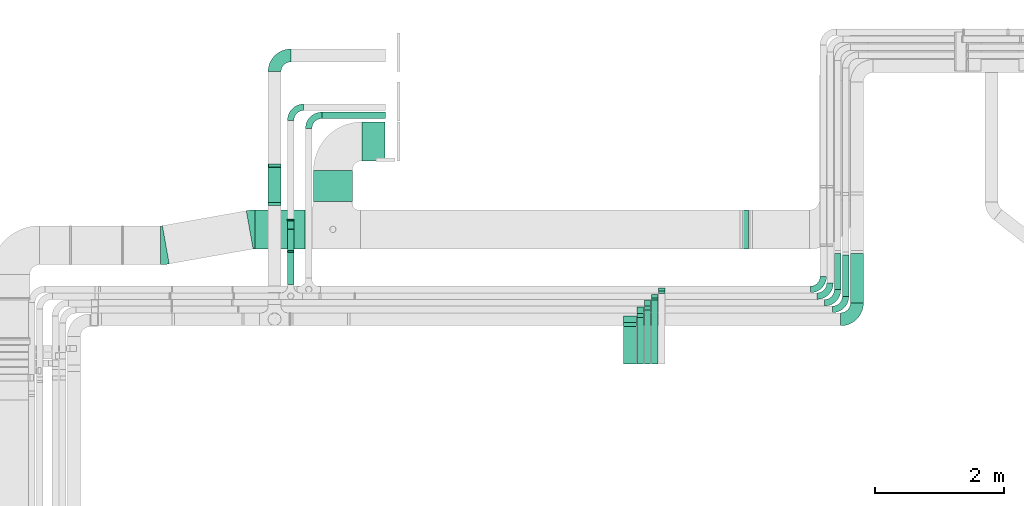
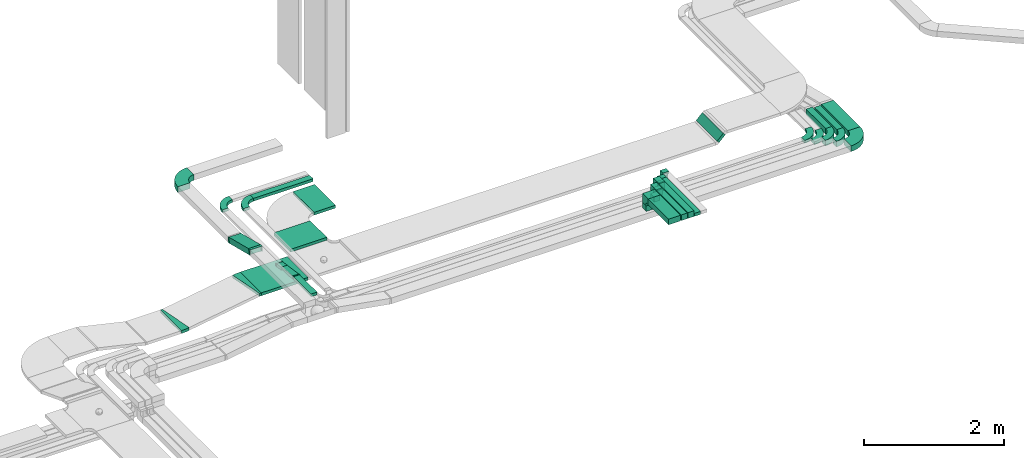
# One storey, part 10 of 28: 21 flow segments, 19 flow fittings.
"""IFC2X3 building model written with IfcOpenShell, lengths in millimetres."""

from ifc_helpers import new_model, entity, si_unit, converted_unit, derived_unit, direction, frame, frame_2d, origin, origin_2d_with_axis, place, context, subcontext, project, spatial, polyline, circle_curve, parameter, trimmed, segment, composite_curve, rectangle, outline, extrude, faceted_brep, source, transform, mapped, material, type_object, type_shapes, element, save


model = new_model("IFC2X3")

# Units and contexts
model_context = context("Model", 3, precision=0.01, world=origin(), true_north=direction((6.12303176911189e-17, 1.0)))
body_context = subcontext(model_context, "Body", "Model", "MODEL_VIEW")
ifc_project = project(units=[si_unit("LENGTHUNIT", "METRE", prefix="MILLI"), si_unit("AREAUNIT", "SQUARE_METRE"), si_unit("VOLUMEUNIT", "CUBIC_METRE"), converted_unit("PLANEANGLEUNIT", "DEGREE", entity("IfcRatioMeasure", 0.0174532925199433), si_unit("PLANEANGLEUNIT", "RADIAN"), dimensions=[0, 0, 0, 0, 0, 0, 0]), si_unit("MASSUNIT", "GRAM", prefix="KILO"), derived_unit("MASSDENSITYUNIT", [(si_unit("MASSUNIT", "GRAM", prefix="KILO"), 1), (si_unit("LENGTHUNIT", "METRE"), -3)]), derived_unit("MOMENTOFINERTIAUNIT", [(si_unit("LENGTHUNIT", "METRE"), 4)]), si_unit("TIMEUNIT", "SECOND"), si_unit("FREQUENCYUNIT", "HERTZ"), si_unit("THERMODYNAMICTEMPERATUREUNIT", "DEGREE_CELSIUS"), derived_unit("THERMALTRANSMITTANCEUNIT", [(si_unit("MASSUNIT", "GRAM", prefix="KILO"), 1), (si_unit("THERMODYNAMICTEMPERATUREUNIT", "KELVIN"), -1), (si_unit("TIMEUNIT", "SECOND"), -3)]), derived_unit("VOLUMETRICFLOWRATEUNIT", [(si_unit("LENGTHUNIT", "METRE"), 3), (si_unit("TIMEUNIT", "SECOND"), -1)]), derived_unit("MASSFLOWRATEUNIT", [(si_unit("MASSUNIT", "GRAM", prefix="KILO"), 1), (si_unit("TIMEUNIT", "SECOND"), -1)]), derived_unit("ROTATIONALFREQUENCYUNIT", [(si_unit("TIMEUNIT", "SECOND"), -1)]), si_unit("ELECTRICCURRENTUNIT", "AMPERE"), si_unit("ELECTRICVOLTAGEUNIT", "VOLT"), si_unit("POWERUNIT", "WATT"), si_unit("FORCEUNIT", "NEWTON", prefix="KILO"), si_unit("ILLUMINANCEUNIT", "LUX"), si_unit("LUMINOUSFLUXUNIT", "LUMEN"), si_unit("LUMINOUSINTENSITYUNIT", "CANDELA"), derived_unit("USERDEFINED", [(si_unit("MASSUNIT", "GRAM", prefix="KILO"), -1), (si_unit("LENGTHUNIT", "METRE"), -2), (si_unit("TIMEUNIT", "SECOND"), 3), (si_unit("LUMINOUSFLUXUNIT", "LUMEN"), 1)]), derived_unit("LINEARVELOCITYUNIT", [(si_unit("LENGTHUNIT", "METRE"), 1), (si_unit("TIMEUNIT", "SECOND"), -1)]), si_unit("PRESSUREUNIT", "PASCAL"), derived_unit("USERDEFINED", [(si_unit("LENGTHUNIT", "METRE"), -2), (si_unit("MASSUNIT", "GRAM", prefix="KILO"), 1), (si_unit("TIMEUNIT", "SECOND"), -2)]), derived_unit("LINEARFORCEUNIT", [(si_unit("MASSUNIT", "GRAM", prefix="KILO"), 1), (si_unit("LENGTHUNIT", "METRE"), 1), (si_unit("TIMEUNIT", "SECOND"), -2), (si_unit("LENGTHUNIT", "METRE"), -1)]), derived_unit("PLANARFORCEUNIT", [(si_unit("MASSUNIT", "GRAM", prefix="KILO"), 1), (si_unit("LENGTHUNIT", "METRE"), 1), (si_unit("TIMEUNIT", "SECOND"), -2), (si_unit("LENGTHUNIT", "METRE"), -2)])], contexts=[model_context])

# Site, building, storey
site_placement = place(None, origin())
site = spatial("IfcSite", under=ifc_project, at=site_placement, CompositionType="ELEMENT")
building_placement = place(site_placement, origin())
building = spatial("IfcBuilding", under=site, at=building_placement, CompositionType="ELEMENT")
storey_placement = place(building_placement, frame((0.0, 0.0, 4200.0)))
storey = spatial("IfcBuildingStorey", under=building, at=storey_placement, CompositionType="ELEMENT", Elevation=4200.0)

# Flow segments
cable_carrier_segment_type = type_object("IfcCableCarrierSegmentType", PredefinedType="CABLETRAYSEGMENT")
flow_segment_1_placement = place(storey_placement, frame((23228.87, 11999.96, 2750.0)))
element("IfcFlowSegment", 1, at=flow_segment_1_placement, inside=storey, type_object=cable_carrier_segment_type, context=body_context, shape_type="SweptSolid", body=[
    extrude(rectangle(XDim=562.575454640019, YDim=100.000000000003, at=origin_2d_with_axis()), frame((50.0, 281.29, 0.0), z_axis=(0.0, 0.0, 1.0), x_axis=(0.0, 1.0, 0.0)), (0.0, 0.0, 1.0), 99.9999999999989),
])
flow_segment_2_placement = place(storey_placement, frame((23353.07, 11897.85, 2750.0)))
element("IfcFlowSegment", 2, at=flow_segment_2_placement, inside=storey, type_object=cable_carrier_segment_type, context=body_context, shape_type="SweptSolid", body=[
    extrude(rectangle(XDim=640.748055056679, YDim=100.000000000003, at=origin_2d_with_axis()), frame((50.0, 320.37, 0.0), z_axis=(0.0, 0.0, 1.0), x_axis=(0.0, 1.0, 0.0)), (0.0, 0.0, 1.0), 99.9999999999989),
])
flow_segment_3_placement = place(storey_placement, frame((23478.99, 11794.79, 2750.0)))
element("IfcFlowSegment", 3, at=flow_segment_3_placement, inside=storey, type_object=cable_carrier_segment_type, context=body_context, shape_type="SweptSolid", body=[
    extrude(rectangle(XDim=764.964137194482, YDim=199.999999999998, at=origin_2d_with_axis()), frame((100.0, 382.48, 0.0), z_axis=(0.0, 0.0, 1.0), x_axis=(0.0, 1.0, 0.0)), (0.0, 0.0, 1.0), 99.9999999999989),
])
flow_segment_4_placement = place(storey_placement, frame((15312.77, 14643.13, 2750.0)))
element("IfcFlowSegment", 4, at=flow_segment_4_placement, inside=storey, type_object=cable_carrier_segment_type, context=body_context, shape_type="SweptSolid", body=[
    extrude(rectangle(XDim=984.53996868844, YDim=99.9999999999989, at=origin_2d_with_axis()), frame((492.27, 50.0, 0.0)), (0.0, 0.0, 1.0), 49.9999999999984),
])
flow_segment_5_placement = place(storey_placement, frame((14483.54, 13326.11, 2759.67)))
element("IfcFlowSegment", 5, at=flow_segment_5_placement, inside=storey, type_object=cable_carrier_segment_type, context=body_context, shape_type="SweptSolid", body=[
    extrude(rectangle(XDim=100.000000000002, YDim=582.930411199209, at=frame_2d((0.0, 0.0), x_axis=(0.0, 1.0))), frame((0.0, 294.88, 119.27), z_axis=(1.0, 0.0, 0.0), x_axis=(0.0, -0.970079574867707, 0.242787187521269)), (0.0, 0.0, 1.0), 200.000000000002),
])
flow_segment_6_placement = place(storey_placement, frame((14783.07, 12081.53, 2820.0)))
element("IfcFlowSegment", 6, at=flow_segment_6_placement, inside=storey, type_object=cable_carrier_segment_type, context=body_context, shape_type="SweptSolid", body=[
    extrude(rectangle(XDim=498.584112619175, YDim=99.9999999999989, at=origin_2d_with_axis()), frame((50.0, 249.29, 0.0), z_axis=(0.0, 0.0, 1.0), x_axis=(0.0, 1.0, 0.0)), (0.0, 0.0, 1.0), 49.9999999999995),
])
flow_segment_7_placement = place(storey_placement, frame((14783.07, 12594.31, 2800.0)))
element("IfcFlowSegment", 7, at=flow_segment_7_placement, inside=storey, type_object=cable_carrier_segment_type, context=body_context, shape_type="SweptSolid", body=[
    extrude(outline(polyline([(-175.75, -24.17), (161.85, -24.17), (161.85, 25.83), (27.82, 25.83), (-175.75, -3.31), (-175.75, -24.17)])), frame((0.0, 163.87, 21.63), z_axis=(1.0, 0.0, 0.0), x_axis=(0.0, -0.989912836483268, 0.141677719369175)), (0.0, 0.0, 1.0), 99.9999999999989),
])
flow_segment_8_placement = place(storey_placement, frame((15184.08, 13362.05, 2682.77)))
element("IfcFlowSegment", 8, at=flow_segment_8_placement, inside=storey, type_object=cable_carrier_segment_type, context=body_context, shape_type="SweptSolid", body=[
    extrude(rectangle(XDim=479.00000000001, YDim=600.000000000002, at=origin_2d_with_axis()), frame((300.0, 239.5, 0.0), z_axis=(0.0, 0.0, 1.0), x_axis=(0.0, 1.0, 0.0)), (0.0, 0.0, 1.0), 49.9999999999995),
])
flow_segment_9_placement = place(storey_placement, frame((15935.08, 13992.05, 2682.77)))
element("IfcFlowSegment", 9, at=flow_segment_9_placement, inside=storey, type_object=cable_carrier_segment_type, context=body_context, shape_type="SweptSolid", body=[
    extrude(rectangle(XDim=354.000000000017, YDim=600.000000000002, at=origin_2d_with_axis()), frame((177.0, 300.0, 0.0)), (0.0, 0.0, 1.0), 49.9999999999984),
])
flow_segment_10_placement = place(storey_placement, frame((14279.85, 12632.05, 2682.77)))
element("IfcFlowSegment", 10, at=flow_segment_10_placement, inside=storey, type_object=cable_carrier_segment_type, context=body_context, shape_type="SweptSolid", body=[
    extrude(rectangle(XDim=774.236305762649, YDim=599.999999999998, at=origin_2d_with_axis()), frame((387.12, 300.0, 0.0), z_axis=(0.0, 0.0, 1.0), x_axis=(-1.0, 0.0, 0.0)), (0.0, 0.0, 1.0), 49.9999999999995),
])
flow_segment_11_placement = place(storey_placement, frame((14783.07, 12928.51, 2751.52)))
element("IfcFlowSegment", 11, at=flow_segment_11_placement, inside=storey, type_object=cable_carrier_segment_type, context=body_context, shape_type="SweptSolid", body=[
    extrude(rectangle(XDim=49.9999999999997, YDim=138.649285066517, at=frame_2d((0.0, 0.0), x_axis=(0.0, 1.0))), frame((0.0, 72.17, 34.57), z_axis=(1.0, 0.0, 0.0), x_axis=(0.0, -0.989912836483268, 0.141677719369175)), (0.0, 0.0, 1.0), 99.9999999999989),
])
flow_segment_12_placement = place(storey_placement, frame((21801.74, 12632.05, 2709.74)))
element("IfcFlowSegment", 12, at=flow_segment_12_placement, inside=storey, type_object=cable_carrier_segment_type, context=body_context, shape_type="SweptSolid", body=[
    extrude(rectangle(XDim=143.47907825232, YDim=49.999999999998, at=origin_2d_with_axis()), frame((68.41, 0.0, 68.41), z_axis=(0.0, 1.0, 0.0), x_axis=(0.707106781186502, 0.0, 0.707106781186593)), (0.0, 0.0, 1.0), 599.999999999998),
])
flow_segment_13_placement = place(storey_placement, frame((20510.96, 11979.03, 2800.0)))
element("IfcFlowSegment", 13, at=flow_segment_13_placement, inside=storey, type_object=cable_carrier_segment_type, context=body_context, shape_type="SweptSolid", body=[
    extrude(rectangle(XDim=100.000000000003, YDim=50.0000000000016, at=origin_2d_with_axis()), frame((50.0, 25.0, 0.0)), (0.0, 0.0, 1.0), 170.000000000004),
])
flow_segment_14_placement = place(storey_placement, frame((20404.36, 10851.67, 3005.0)))
element("IfcFlowSegment", 14, at=flow_segment_14_placement, inside=storey, type_object=cable_carrier_segment_type, context=body_context, shape_type="SweptSolid", body=[
    extrude(rectangle(XDim=987.987059231862, YDim=100.000000000003, at=origin_2d_with_axis()), frame((50.0, 493.99, 0.0), z_axis=(0.0, 0.0, 1.0), x_axis=(0.0, -1.0, 0.0)), (0.0, 0.0, 1.0), 50.0000000000005),
])
flow_segment_15_placement = place(storey_placement, frame((20404.27, 11874.48, 2800.0)))
element("IfcFlowSegment", 15, at=flow_segment_15_placement, inside=storey, type_object=cable_carrier_segment_type, context=body_context, shape_type="SweptSolid", body=[
    extrude(rectangle(XDim=100.000000000004, YDim=50.000000000002, at=origin_2d_with_axis()), frame((50.09, 25.18, 0.0), z_axis=(0.0, 0.0, 1.0), x_axis=(0.999993574881429, -0.00358471698463083, 0.0)), (0.0, 0.0, 1.0), 170.000000000003),
])
flow_segment_16_placement = place(storey_placement, frame((20293.85, 10851.67, 3005.0)))
element("IfcFlowSegment", 16, at=flow_segment_16_placement, inside=storey, type_object=cable_carrier_segment_type, context=body_context, shape_type="SweptSolid", body=[
    extrude(rectangle(XDim=833.264768275426, YDim=100.000000000003, at=origin_2d_with_axis()), frame((50.0, 416.63, 0.0), z_axis=(0.0, 0.0, 1.0), x_axis=(0.0, -1.0, 0.0)), (0.0, 0.0, 1.0), 99.9999999999989),
])
flow_segment_17_placement = place(storey_placement, frame((20293.85, 11744.94, 2850.05)))
element("IfcFlowSegment", 17, at=flow_segment_17_placement, inside=storey, type_object=cable_carrier_segment_type, context=body_context, shape_type="SweptSolid", body=[
    extrude(rectangle(XDim=100.00000001767, YDim=99.9999999999989, at=origin_2d_with_axis()), frame((50.0, 50.0, 0.0), z_axis=(1.87970794378071e-05, 0.0, 1.0), x_axis=(-1.0, 0.0, 1.87970794378071e-05)), (1.87970794378071e-05, 0.0, 1.0), 94.9448301466394),
])
flow_segment_18_placement = place(storey_placement, frame((20183.77, 11633.74, 2850.0)))
element("IfcFlowSegment", 18, at=flow_segment_18_placement, inside=storey, type_object=cable_carrier_segment_type, context=body_context, shape_type="SweptSolid", body=[
    extrude(rectangle(XDim=100.000000000003, YDim=99.9999999999989, at=origin_2d_with_axis()), frame((50.0, 50.0, 0.0)), (0.0, 0.0, 1.0), 95.0000000000066),
])
flow_segment_19_placement = place(storey_placement, frame((20183.77, 10851.67, 3005.0)))
element("IfcFlowSegment", 19, at=flow_segment_19_placement, inside=storey, type_object=cable_carrier_segment_type, context=body_context, shape_type="SweptSolid", body=[
    extrude(rectangle(XDim=722.071404339018, YDim=100.000000000003, at=origin_2d_with_axis()), frame((50.0, 361.04, 0.0), z_axis=(0.0, 0.0, 1.0), x_axis=(0.0, -1.0, 0.0)), (0.0, 0.0, 1.0), 99.9999999999989),
])
flow_segment_20_placement = place(storey_placement, frame((19972.93, 10851.67, 3005.0)))
element("IfcFlowSegment", 20, at=flow_segment_20_placement, inside=storey, type_object=cable_carrier_segment_type, context=body_context, shape_type="SweptSolid", body=[
    extrude(rectangle(XDim=582.112679578124, YDim=199.999999999998, at=origin_2d_with_axis()), frame((100.0, 291.06, 0.0), z_axis=(0.0, 0.0, 1.0), x_axis=(0.0, -1.0, 0.0)), (0.0, 0.0, 1.0), 99.9999999999978),
])
flow_segment_21_placement = place(storey_placement, frame((19972.93, 11493.79, 2850.0)))
element("IfcFlowSegment", 21, at=flow_segment_21_placement, inside=storey, type_object=cable_carrier_segment_type, context=body_context, shape_type="SweptSolid", body=[
    extrude(rectangle(XDim=199.999999999998, YDim=99.9999999999989, at=origin_2d_with_axis()), frame((100.0, 50.0, 0.0), z_axis=(0.0, 0.0, 1.0), x_axis=(-1.0, 0.0, 0.0)), (0.0, 0.0, 1.0), 94.9999999999979),
])

# Flow fittings
ifc_material = material()
cable_carrier_fitting_type_1 = type_object("IfcCableCarrierFittingType", PredefinedType="NOTDEFINED", material=ifc_material)
shared_shape_1 = source(origin(), body_context, "Body", "Brep", [
    faceted_brep([(-17.94, -50.0, 100.0), (-17.94, 50.0, 100.0), (-17.94, 50.0, 97.46), (-17.94, -47.46, 97.46), (-17.94, -47.46, -97.46), (-17.94, 50.0, -97.46), (-17.94, 50.0, -100.0), (-17.94, -50.0, -100.0), (29.54, -44.15, 100.0), (29.54, -44.15, -100.0), (5.26, 52.86, -100.0), (5.26, 52.86, -97.46), (28.93, -41.68, -97.46), (28.93, -41.68, 97.46), (5.26, 52.86, 97.46), (5.26, 52.86, 100.0), (6.16, -50.0, 100.0), (-6.16, 50.0, 100.0), (-6.16, 50.0, 97.46), (5.85, -47.46, 97.46), (5.85, -47.46, -97.46), (-6.16, 50.0, -97.46), (-6.16, 50.0, -100.0), (6.16, -50.0, -100.0)], [[[0, 1, 2, 3, 4, 5, 6, 7]], [[8, 9, 10, 11, 12, 13, 14, 15]], [[1, 0, 16, 8, 15, 17]], [[2, 1, 17, 18]], [[3, 2, 18, 14, 13, 19]], [[4, 3, 19, 20]], [[5, 4, 20, 12, 11, 21]], [[6, 5, 21, 22]], [[7, 6, 22, 10, 9, 23]], [[0, 7, 23, 16]], [[18, 17, 15, 14]], [[20, 19, 13, 12]], [[22, 21, 11, 10]], [[16, 23, 9, 8]]]),
])
type_shapes(cable_carrier_fitting_type_1, [shared_shape_1])
for number, where, z_axis, x_axis in (
    (22, (14583.54, 13320.85, 2954.06), (-1.0, 0.0, 0.0), (0.0, 1.0, 0.0)),
    (23, (14583.54, 13921.14, 2803.82), (1.0, 0.0, 0.0), (0.0, 0.970079574867707, -0.242787187521269)),
):
    element("IfcFlowFitting", number, at=place(storey_placement, frame(where, z_axis=z_axis, x_axis=x_axis)), inside=storey, type_object=cable_carrier_fitting_type_1, material=ifc_material, context=body_context, shape_type="MappedRepresentation", body=[
        mapped(shared_shape_1, transform((0.0, 0.0, 0.0), scale=1.0)),
    ])
cable_carrier_fitting_type_2 = type_object("IfcCableCarrierFittingType", PredefinedType="NOTDEFINED", material=ifc_material)
shared_shape_2 = source(origin(), body_context, "Body", "Brep", [
    faceted_brep([(-8.92, -25.0, 50.0), (-8.92, 25.0, 50.0), (-8.92, 25.0, 47.46), (-8.92, -22.46, 47.46), (-8.92, -22.46, -47.46), (-8.92, 25.0, -47.46), (-8.92, 25.0, -50.0), (-8.92, -25.0, -50.0), (12.37, -23.48, 50.0), (12.37, -23.48, -50.0), (5.28, 26.01, -50.0), (5.28, 26.01, -47.46), (12.01, -20.97, -47.46), (12.01, -20.97, 47.46), (5.28, 26.01, 47.46), (5.28, 26.01, 50.0), (1.78, -25.0, 50.0), (-1.78, 25.0, 50.0), (-1.78, 25.0, 47.46), (1.6, -22.46, 47.46), (1.6, -22.46, -47.46), (-1.78, 25.0, -47.46), (-1.78, 25.0, -50.0), (1.78, -25.0, -50.0)], [[[0, 1, 2, 3, 4, 5, 6, 7]], [[8, 9, 10, 11, 12, 13, 14, 15]], [[1, 0, 16, 8, 15, 17]], [[2, 1, 17, 18]], [[3, 2, 18, 14, 13, 19]], [[4, 3, 19, 20]], [[5, 4, 20, 12, 11, 21]], [[6, 5, 21, 22]], [[7, 6, 22, 10, 9, 23]], [[0, 7, 23, 16]], [[18, 17, 15, 14]], [[20, 19, 13, 12]], [[22, 21, 11, 10]], [[16, 23, 9, 8]]]),
])
type_shapes(cable_carrier_fitting_type_2, [shared_shape_2])
for number, where, z_axis, x_axis in (
    (24, (14833.07, 13078.13, 2775.0), (-1.0, 0.0, 0.0), (0.0, -1.0, 0.0)),
    (25, (14833.07, 12589.03, 2845.0), (-1.0, 0.0, 0.0), (0.0, 1.0, 0.0)),
):
    element("IfcFlowFitting", number, at=place(storey_placement, frame(where, z_axis=z_axis, x_axis=x_axis)), inside=storey, type_object=cable_carrier_fitting_type_2, material=ifc_material, context=body_context, shape_type="MappedRepresentation", body=[
        mapped(shared_shape_2, transform((0.0, 0.0, 0.0), scale=1.0)),
    ])
cable_carrier_fitting_type_3 = type_object("IfcCableCarrierFittingType", PredefinedType="NOTDEFINED", material=ifc_material)
shared_shape_3 = source(origin(), body_context, "Body", "Brep", [
    faceted_brep([(-110.0, -50.0, 100.0), (-110.0, 50.0, 100.0), (-110.0, 50.0, 97.46), (-110.0, -47.46, 97.46), (-110.0, -47.46, -97.46), (-110.0, 50.0, -97.46), (-110.0, 50.0, -100.0), (-110.0, -50.0, -100.0), (50.0, 110.0, 100.0), (50.0, 110.0, -100.0), (-50.0, 110.0, -100.0), (-50.0, 110.0, -97.46), (47.46, 110.0, -97.46), (47.46, 110.0, 97.46), (-50.0, 110.0, 97.46), (-50.0, 110.0, 100.0), (50.0, -50.0, 100.0), (-50.0, 50.0, 100.0), (-50.0, 50.0, 97.46), (47.46, -47.46, 97.46), (47.46, -47.46, -97.46), (-50.0, 50.0, -97.46), (-50.0, 50.0, -100.0), (50.0, -50.0, -100.0)], [[[0, 1, 2, 3, 4, 5, 6, 7]], [[8, 9, 10, 11, 12, 13, 14, 15]], [[1, 0, 16, 8, 15, 17]], [[2, 1, 17, 18]], [[3, 2, 18, 14, 13, 19]], [[4, 3, 19, 20]], [[5, 4, 20, 12, 11, 21]], [[6, 5, 21, 22]], [[7, 6, 22, 10, 9, 23]], [[0, 7, 23, 16]], [[18, 17, 15, 14]], [[20, 19, 13, 12]], [[22, 21, 11, 10]], [[16, 23, 9, 8]]]),
])
type_shapes(cable_carrier_fitting_type_3, [shared_shape_3])
flow_fitting_1_placement = place(storey_placement, frame((20072.93, 11543.79, 3055.0), z_axis=(-1.0, 0.0, 0.0), x_axis=(0.0, 1.0, 0.0)))
element("IfcFlowFitting", 26, at=flow_fitting_1_placement, inside=storey, type_object=cable_carrier_fitting_type_3, material=ifc_material, context=body_context, shape_type="MappedRepresentation", body=[
    mapped(shared_shape_3, transform((0.0, 0.0, 0.0), scale=1.0)),
])
cable_carrier_fitting_type_4 = type_object("IfcCableCarrierFittingType", PredefinedType="NOTDEFINED", material=ifc_material)
shared_shape_4 = source(origin(), body_context, "Body", "Brep", [
    faceted_brep([(-110.0, -50.0, 50.0), (-110.0, 50.0, 50.0), (-110.0, 50.0, 47.46), (-110.0, -47.46, 47.46), (-110.0, -47.46, -47.46), (-110.0, 50.0, -47.46), (-110.0, 50.0, -50.0), (-110.0, -50.0, -50.0), (50.0, 110.0, 50.0), (50.0, 110.0, -50.0), (-50.0, 110.0, -50.0), (-50.0, 110.0, -47.46), (47.46, 110.0, -47.46), (47.46, 110.0, 47.46), (-50.0, 110.0, 47.46), (-50.0, 110.0, 50.0), (50.0, -50.0, 50.0), (-50.0, 50.0, 50.0), (-50.0, 50.0, 47.46), (47.46, -47.46, 47.46), (47.46, -47.46, -47.46), (-50.0, 50.0, -47.46), (-50.0, 50.0, -50.0), (50.0, -50.0, -50.0)], [[[0, 1, 2, 3, 4, 5, 6, 7]], [[8, 9, 10, 11, 12, 13, 14, 15]], [[1, 0, 16, 8, 15, 17]], [[2, 1, 17, 18]], [[3, 2, 18, 14, 13, 19]], [[4, 3, 19, 20]], [[5, 4, 20, 12, 11, 21]], [[6, 5, 21, 22]], [[7, 6, 22, 10, 9, 23]], [[0, 7, 23, 16]], [[18, 17, 15, 14]], [[20, 19, 13, 12]], [[22, 21, 11, 10]], [[16, 23, 9, 8]]]),
])
type_shapes(cable_carrier_fitting_type_4, [shared_shape_4])
for number, where, z_axis, x_axis in (
    (27, (20343.85, 11794.94, 3055.0), (-1.0, 0.0, 0.0), (0.0, 1.0, 0.0)),
    (28, (20233.77, 11683.74, 3055.0), (-1.0, 0.0, 0.0), (0.0, 1.0, 0.0)),
):
    element("IfcFlowFitting", number, at=place(storey_placement, frame(where, z_axis=z_axis, x_axis=x_axis)), inside=storey, type_object=cable_carrier_fitting_type_4, material=ifc_material, context=body_context, shape_type="MappedRepresentation", body=[
        mapped(shared_shape_4, transform((0.0, 0.0, 0.0), scale=1.0)),
    ])
cable_carrier_fitting_type_5 = type_object("IfcCableCarrierFittingType", PredefinedType="NOTDEFINED", material=ifc_material)
shared_shape_5 = source(origin(), body_context, "Body", "Brep", [
    faceted_brep([(-60.0, -25.0, 50.0), (-60.0, 25.0, 50.0), (-60.0, 25.0, 47.46), (-60.0, -22.46, 47.46), (-60.0, -22.46, -47.46), (-60.0, 25.0, -47.46), (-60.0, 25.0, -50.0), (-60.0, -25.0, -50.0), (25.0, 60.0, 50.0), (25.0, 60.0, -50.0), (-25.0, 60.0, -50.0), (-25.0, 60.0, -47.46), (22.46, 60.0, -47.46), (22.46, 60.0, 47.46), (-25.0, 60.0, 47.46), (-25.0, 60.0, 50.0), (25.0, -25.0, 50.0), (-25.0, 25.0, 50.0), (-25.0, 25.0, 47.46), (22.46, -22.46, 47.46), (22.46, -22.46, -47.46), (-25.0, 25.0, -47.46), (-25.0, 25.0, -50.0), (25.0, -25.0, -50.0)], [[[0, 1, 2, 3, 4, 5, 6, 7]], [[8, 9, 10, 11, 12, 13, 14, 15]], [[1, 0, 16, 8, 15, 17]], [[2, 1, 17, 18]], [[3, 2, 18, 14, 13, 19]], [[4, 3, 19, 20]], [[5, 4, 20, 12, 11, 21]], [[6, 5, 21, 22]], [[7, 6, 22, 10, 9, 23]], [[0, 7, 23, 16]], [[18, 17, 15, 14]], [[20, 19, 13, 12]], [[22, 21, 11, 10]], [[16, 23, 9, 8]]]),
])
type_shapes(cable_carrier_fitting_type_5, [shared_shape_5])
for number, where, z_axis, x_axis in (
    (29, (20454.36, 11899.66, 3030.0), (1.0, 0.0, 0.0), (0.0, 0.0, 1.0)),
    (30, (20560.96, 12004.03, 3030.0), (1.0, 0.0, 0.0), (0.0, 0.0, 1.0)),
):
    element("IfcFlowFitting", number, at=place(storey_placement, frame(where, z_axis=z_axis, x_axis=x_axis)), inside=storey, type_object=cable_carrier_fitting_type_5, material=ifc_material, context=body_context, shape_type="MappedRepresentation", body=[
        mapped(shared_shape_5, transform((0.0, 0.0, 0.0), scale=1.0)),
    ])
cable_carrier_fitting_type_6 = type_object("IfcCableCarrierFittingType", Name="470_DKC_S5_Variable Angle Elbow 0-45:-", PredefinedType="NOTDEFINED", material=ifc_material)
shared_shape_6 = source(origin(), body_context, "Body", "SweptSolid", [
    extrude(outline(composite_curve([segment(polyline([(-125.75, -225.25), (-124.75, -225.25)]), True, "CONTINUOUS"), segment(trimmed(circle_curve(frame_2d((-124.75, 124.75), x_axis=(0.0, -1.0)), 350.0), [parameter(0.0)], [parameter(90.0000000000001)], True, "PARAMETER"), True, "CONTINUOUS"), segment(polyline([(225.25, 124.75), (225.25, 125.75)]), True, "CONTINUOUS"), segment(polyline([(225.25, 125.75), (25.25, 125.75)]), True, "CONTINUOUS"), segment(polyline([(25.25, 125.75), (25.25, 124.75)]), True, "CONTINUOUS"), segment(trimmed(circle_curve(frame_2d((-124.75, 124.75), x_axis=(0.0, -1.0)), 150.0), [parameter(0.0)], [parameter(90.0000000000001)], True, "PARAMETER"), False, "CONTINUOUS"), segment(polyline([(-124.75, -25.25), (-125.75, -25.25)]), True, "CONTINUOUS"), segment(polyline([(-125.75, -25.25), (-125.75, -225.25)]), True, "CONTINUOUS")], self_intersect=False)), frame((-125.25, 125.25, -50.0)), (0.0, 0.0, 1.0), 100.0),
])
type_shapes(cable_carrier_fitting_type_6, [shared_shape_6])
flow_fitting_2_placement = place(storey_placement, frame((14583.54, 15618.13, 2803.82), z_axis=(0.0, 0.0, 1.0), x_axis=(-1.0, 0.0, 0.0)))
element("IfcFlowFitting", 31, at=flow_fitting_2_placement, inside=storey, type_object=cable_carrier_fitting_type_6, material=ifc_material, Name="470_DKC_S5_Variable Angle Elbow 0-45:-", ObjectType="470_DKC_S5_Variable Angle Elbow 0-45:-", context=body_context, shape_type="MappedRepresentation", body=[
    mapped(shared_shape_6, transform((0.0, 0.0, 0.0), scale=1.0)),
])
flow_fitting_3_placement = place(storey_placement, frame((23578.99, 11543.79, 2800.0)))
element("IfcFlowFitting", 32, at=flow_fitting_3_placement, inside=storey, type_object=cable_carrier_fitting_type_6, material=ifc_material, Name="470_DKC_S5_Variable Angle Elbow 0-45:-", ObjectType="470_DKC_S5_Variable Angle Elbow 0-45:-", context=body_context, shape_type="MappedRepresentation", body=[
    mapped(shared_shape_6, transform((0.0, 0.0, 0.0), scale=1.0)),
])
cable_carrier_fitting_type_7 = type_object("IfcCableCarrierFittingType", Name="470_DKC_S5_Variable Angle Elbow 0-45:-", PredefinedType="NOTDEFINED", material=ifc_material)
shared_shape_7 = source(origin(), body_context, "Body", "SweptSolid", [
    extrude(outline(composite_curve([segment(polyline([(-100.75, -150.25), (-99.75, -150.25)]), True, "CONTINUOUS"), segment(trimmed(circle_curve(frame_2d((-99.75, 99.75), x_axis=(0.0, -1.0)), 250.0), [parameter(0.0)], [parameter(90.0000000000001)], True, "PARAMETER"), True, "CONTINUOUS"), segment(polyline([(150.25, 99.75), (150.25, 100.75)]), True, "CONTINUOUS"), segment(polyline([(150.25, 100.75), (50.25, 100.75)]), True, "CONTINUOUS"), segment(polyline([(50.25, 100.75), (50.25, 99.75)]), True, "CONTINUOUS"), segment(trimmed(circle_curve(frame_2d((-99.75, 99.75), x_axis=(0.0, -1.0)), 150.0), [parameter(0.0)], [parameter(90.0000000000001)], True, "PARAMETER"), False, "CONTINUOUS"), segment(polyline([(-99.75, -50.25), (-100.75, -50.25)]), True, "CONTINUOUS"), segment(polyline([(-100.75, -50.25), (-100.75, -150.25)]), True, "CONTINUOUS")], self_intersect=False)), frame((-100.25, 100.25, -25.0)), (0.0, 0.0, 1.0), 49.9999999999997),
])
type_shapes(cable_carrier_fitting_type_7, [shared_shape_7])
flow_fitting_4_placement = place(storey_placement, frame((23163.07, 11901.53, 2775.0)))
element("IfcFlowFitting", 33, at=flow_fitting_4_placement, inside=storey, type_object=cable_carrier_fitting_type_7, material=ifc_material, Name="470_DKC_S5_Variable Angle Elbow 0-45:-", ObjectType="470_DKC_S5_Variable Angle Elbow 0-45:-", context=body_context, shape_type="MappedRepresentation", body=[
    mapped(shared_shape_7, transform((0.0, 0.0, 0.0), scale=1.0)),
])
flow_fitting_5_placement = place(storey_placement, frame((14833.07, 14818.13, 2775.0), z_axis=(0.0, 0.0, 1.0), x_axis=(-1.0, 0.0, 0.0)))
element("IfcFlowFitting", 34, at=flow_fitting_5_placement, inside=storey, type_object=cable_carrier_fitting_type_7, material=ifc_material, Name="470_DKC_S5_Variable Angle Elbow 0-45:-", ObjectType="470_DKC_S5_Variable Angle Elbow 0-45:-", context=body_context, shape_type="MappedRepresentation", body=[
    mapped(shared_shape_7, transform((0.0, 0.0, 0.0), scale=1.0)),
])
flow_fitting_6_placement = place(storey_placement, frame((23058.87, 12004.03, 2775.0)))
element("IfcFlowFitting", 35, at=flow_fitting_6_placement, inside=storey, type_object=cable_carrier_fitting_type_7, material=ifc_material, Name="470_DKC_S5_Variable Angle Elbow 0-45:-", ObjectType="470_DKC_S5_Variable Angle Elbow 0-45:-", context=body_context, shape_type="MappedRepresentation", body=[
    mapped(shared_shape_7, transform((0.0, 0.0, 0.0), scale=1.0)),
])
flow_fitting_7_placement = place(storey_placement, frame((15111.77, 14693.13, 2775.0), z_axis=(0.0, 0.0, 1.0), x_axis=(-1.0, 0.0, 0.0)))
element("IfcFlowFitting", 36, at=flow_fitting_7_placement, inside=storey, type_object=cable_carrier_fitting_type_7, material=ifc_material, Name="470_DKC_S5_Variable Angle Elbow 0-45:-", ObjectType="470_DKC_S5_Variable Angle Elbow 0-45:-", context=body_context, shape_type="MappedRepresentation", body=[
    mapped(shared_shape_7, transform((0.0, 0.0, 0.0), scale=1.0)),
])
cable_carrier_fitting_type_8 = type_object("IfcCableCarrierFittingType", Name="470_DKC_S5_Variable Angle Elbow 0-45:-", PredefinedType="NOTDEFINED", material=ifc_material)
shared_shape_8 = source(origin(), body_context, "Body", "SweptSolid", [
    extrude(outline(composite_curve([segment(polyline([(-100.75, -150.25), (-99.75, -150.25)]), True, "CONTINUOUS"), segment(trimmed(circle_curve(frame_2d((-99.75, 99.75), x_axis=(0.0, -1.0)), 250.0), [parameter(0.0)], [parameter(90.0000000000001)], True, "PARAMETER"), True, "CONTINUOUS"), segment(polyline([(150.25, 99.75), (150.25, 100.75)]), True, "CONTINUOUS"), segment(polyline([(150.25, 100.75), (50.25, 100.75)]), True, "CONTINUOUS"), segment(polyline([(50.25, 100.75), (50.25, 99.75)]), True, "CONTINUOUS"), segment(trimmed(circle_curve(frame_2d((-99.75, 99.75), x_axis=(0.0, -1.0)), 150.0), [parameter(0.0)], [parameter(90.0000000000001)], True, "PARAMETER"), False, "CONTINUOUS"), segment(polyline([(-99.75, -50.25), (-100.75, -50.25)]), True, "CONTINUOUS"), segment(polyline([(-100.75, -50.25), (-100.75, -150.25)]), True, "CONTINUOUS")], self_intersect=False)), frame((-100.25, 100.25, -50.0)), (0.0, 0.0, 1.0), 100.0),
])
type_shapes(cable_carrier_fitting_type_8, [shared_shape_8])
for number, where, name in (
    (37, (23403.07, 11696.85, 2800.0), "470_DKC_S5_Variable Angle Elbow 0-45:-"),
    (38, (23278.87, 11798.96, 2800.0), "470_DKC_S5_Variable Angle Elbow 0-45:-"),
):
    element("IfcFlowFitting", number, at=place(storey_placement, frame(where)), inside=storey, type_object=cable_carrier_fitting_type_8, material=ifc_material, Name=name, ObjectType="470_DKC_S5_Variable Angle Elbow 0-45:-", context=body_context, shape_type="MappedRepresentation", body=[
        mapped(shared_shape_8, transform((0.0, 0.0, 0.0), scale=1.0)),
    ])
cable_carrier_fitting_type_9 = type_object("IfcCableCarrierFittingType", Name="470_DKC_S5_Variable Angle Elbow 0-45:-", PredefinedType="NOTDEFINED", material=ifc_material)
shared_shape_9 = source(origin(), body_context, "Body", "SweptSolid", [
    extrude(outline(composite_curve([segment(polyline([(-40.45, -303.53), (-39.45, -303.53)]), True, "CONTINUOUS"), segment(trimmed(circle_curve(frame_2d((-39.45, 446.47), x_axis=(0.0, -1.0)), 750.0), [parameter(0.0)], [parameter(10.0995099197509)], True, "PARAMETER"), True, "CONTINUOUS"), segment(polyline([(92.07, -291.91), (93.05, -291.73)]), True, "CONTINUOUS"), segment(polyline([(93.05, -291.73), (-12.16, 298.97)]), True, "CONTINUOUS"), segment(polyline([(-12.16, 298.97), (-13.15, 298.79)]), True, "CONTINUOUS"), segment(trimmed(circle_curve(frame_2d((-39.45, 446.47), x_axis=(0.0, -1.0)), 150.0), [parameter(0.0)], [parameter(10.0995099197509)], True, "PARAMETER"), False, "CONTINUOUS"), segment(polyline([(-39.45, 296.47), (-40.45, 296.47)]), True, "CONTINUOUS"), segment(polyline([(-40.45, 296.47), (-40.45, -303.53)]), True, "CONTINUOUS")], self_intersect=False)), frame((-0.31, 3.53, -25.0)), (0.0, 0.0, 1.0), 50.0000000000017),
])
type_shapes(cable_carrier_fitting_type_9, [shared_shape_9])
flow_fitting_8_placement = place(storey_placement, frame((14239.08, 12932.05, 2707.77), z_axis=(0.0, 0.0, 1.0), x_axis=(-1.0, 0.0, 0.0)))
element("IfcFlowFitting", 39, at=flow_fitting_8_placement, inside=storey, type_object=cable_carrier_fitting_type_9, material=ifc_material, Name="470_DKC_S5_Variable Angle Elbow 0-45:-", ObjectType="470_DKC_S5_Variable Angle Elbow 0-45:-", context=body_context, shape_type="MappedRepresentation", body=[
    mapped(shared_shape_9, transform((0.0, 0.0, 0.0), scale=1.0)),
])
flow_fitting_9_placement = place(storey_placement, frame((12863.59, 12687.05, 2707.77)))
element("IfcFlowFitting", 40, at=flow_fitting_9_placement, inside=storey, type_object=cable_carrier_fitting_type_9, material=ifc_material, Name="470_DKC_S5_Variable Angle Elbow 0-45:-", ObjectType="470_DKC_S5_Variable Angle Elbow 0-45:-", context=body_context, shape_type="MappedRepresentation", body=[
    mapped(shared_shape_9, transform((0.0, 0.0, 0.0), scale=1.0)),
])

save(model, "model.ifc")
